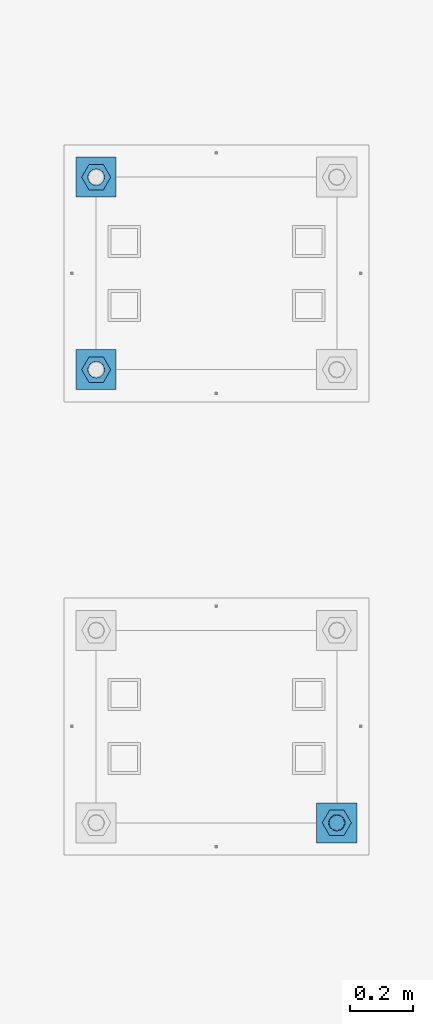
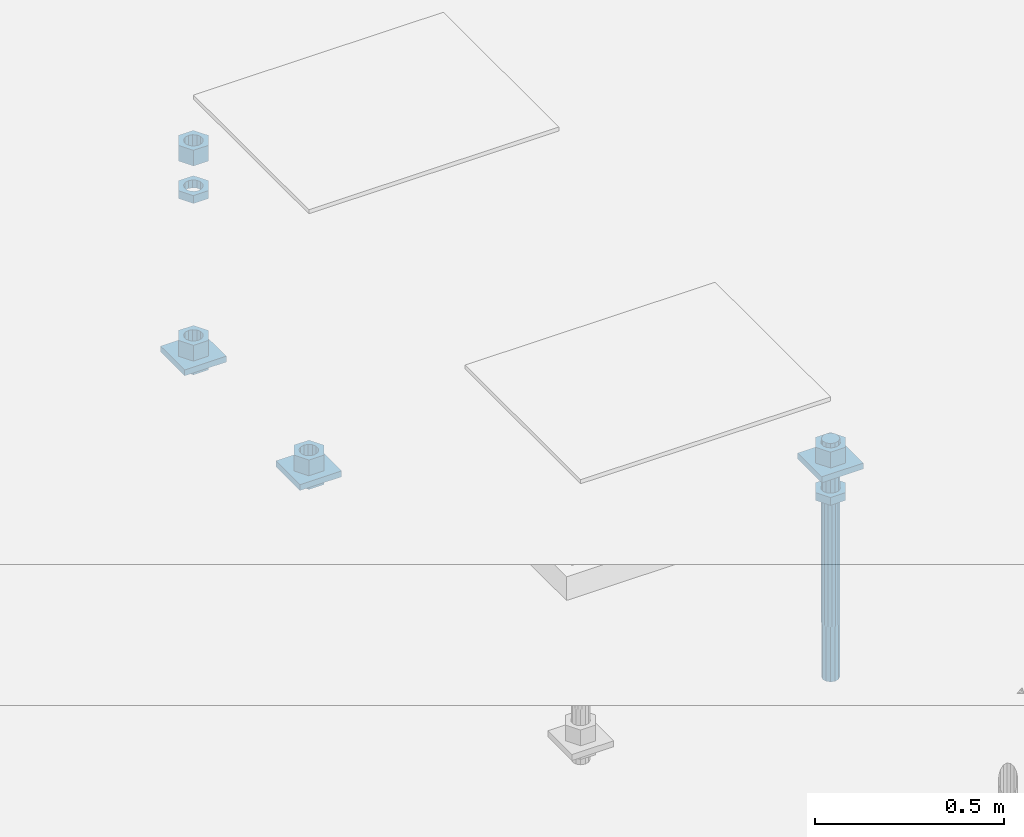
# One storey, part 2560 of 3843: 12 beams, 2 elements without a shape of their own.
"""IFC2X3 building model written with IfcOpenShell, lengths in millimetres."""

from ifc_helpers import new_model, si_unit, frame, origin_with_axes, place, context, subcontext, project, spatial, faceted_brep, material, type_object, element, aggregate, save


model = new_model("IFC2X3")

# Units and contexts
model_context = context("Model", 3, precision=1e-05, world=origin_with_axes())
body_context = subcontext(model_context, "Body", "Model", "MODEL_VIEW")
ifc_project = project(units=[si_unit("LENGTHUNIT", "METRE", prefix="MILLI"), si_unit("AREAUNIT", "SQUARE_METRE"), si_unit("VOLUMEUNIT", "CUBIC_METRE"), si_unit("MASSUNIT", "GRAM", prefix="KILO"), si_unit("TIMEUNIT", "SECOND"), si_unit("PLANEANGLEUNIT", "RADIAN"), si_unit("SOLIDANGLEUNIT", "STERADIAN"), si_unit("THERMODYNAMICTEMPERATUREUNIT", "DEGREE_CELSIUS"), si_unit("LUMINOUSINTENSITYUNIT", "LUMEN")], contexts=[model_context])

# Site, building, storey
site_placement = place(None, origin_with_axes())
site = spatial("IfcSite", under=ifc_project, at=site_placement, CompositionType="ELEMENT")
building_placement = place(site_placement, origin_with_axes())
building = spatial("IfcBuilding", under=site, at=building_placement, Name="Undefined", CompositionType="ELEMENT")
storey_placement = place(building_placement, origin_with_axes())
storey = spatial("IfcBuildingStorey", under=building, at=storey_placement, Name="Undefined", CompositionType="ELEMENT", Elevation=0.0)

# Assembly, beam
assembly_1_placement = place(storey_placement, origin_with_axes())
assembly_1 = element("IfcElementAssembly", 1, at=assembly_1_placement, inside=storey, Name="TEMPLATE", AssemblyPlace="NOTDEFINED", PredefinedType="RIGID_FRAME")
ifc_material_1 = material(Name="STEEL/A572-50")
beam_type_1 = type_object("IfcBeamType", PredefinedType="NOTDEFINED")
beam_1_placement = place(assembly_1_placement, frame((105537.0, 1282.70000152587, 29873.575), z_axis=(1.0, 0.0, 0.0), x_axis=(0.0, 1.0, 0.0)))
beam_1 = element("IfcBeam", 2, at=beam_1_placement, type_object=beam_type_1, material=ifc_material_1, Name="WASHER_PLATE", context=body_context, shape_type="Brep", body=[
    faceted_brep([(0.0, 9.52500000000146, -63.5), (0.0, 9.52500000000146, 63.5), (127.0, 9.52500000000146, 63.5), (127.0, 9.52500000000146, -63.5), (0.0, -9.52500000000146, 63.5), (127.0, -9.52500000000146, 63.5), (0.0, -9.52500000000146, -63.5), (127.0, -9.52500000000146, -63.5)], [[[0, 1, 2, 3]], [[1, 4, 5, 2]], [[4, 6, 7, 5]], [[6, 0, 3, 7]], [[5, 7, 3, 2]], [[6, 4, 1, 0]]]),
])

# Assembly, beams
assembly_2_placement = place(storey_placement, origin_with_axes())
assembly_2 = element("IfcElementAssembly", 3, at=assembly_2_placement, inside=storey, Name="TEMPLATE", AssemblyPlace="NOTDEFINED", PredefinedType="RIGID_FRAME")
beam_2_placement = place(assembly_2_placement, frame((104775.0, 2717.80000152587, 29244.925), z_axis=(1.0, 0.0, 0.0), x_axis=(0.0, 1.0, 0.0)))
beam_2 = element("IfcBeam", 4, at=beam_2_placement, type_object=beam_type_1, material=ifc_material_1, Name="WASHER_PLATE", context=body_context, shape_type="Brep", body=[
    faceted_brep([(0.0, 9.52500000000146, -63.5), (0.0, 9.52500000000146, 63.5), (127.0, 9.52500000000146, 63.5), (127.0, 9.52500000000146, -63.5), (0.0, -9.52500000000146, 63.5), (127.0, -9.52500000000146, 63.5), (0.0, -9.52500000000146, -63.5), (127.0, -9.52500000000146, -63.5)], [[[0, 1, 2, 3]], [[1, 4, 5, 2]], [[4, 6, 7, 5]], [[6, 0, 3, 7]], [[5, 7, 3, 2]], [[6, 4, 1, 0]]]),
])
beam_3_placement = place(assembly_2_placement, frame((104775.0, 3327.40000152587, 29244.925), z_axis=(1.0, 0.0, 0.0), x_axis=(0.0, 1.0, 0.0)))
beam_3 = element("IfcBeam", 5, at=beam_3_placement, type_object=beam_type_1, material=ifc_material_1, Name="WASHER_PLATE", context=body_context, shape_type="Brep", body=[
    faceted_brep([(0.0, 9.52500000000146, -63.5), (0.0, 9.52500000000146, 63.5), (127.0, 9.52500000000146, 63.5), (127.0, 9.52500000000146, -63.5), (0.0, -9.52500000000146, 63.5), (127.0, -9.52500000000146, 63.5), (0.0, -9.52500000000146, -63.5), (127.0, -9.52500000000146, -63.5)], [[[0, 1, 2, 3]], [[1, 4, 5, 2]], [[4, 6, 7, 5]], [[6, 0, 3, 7]], [[5, 7, 3, 2]], [[6, 4, 1, 0]]]),
])

# Beam
ifc_material_2 = material(Name="STEEL/A36")
beam_type_2 = type_object("IfcBeamType", Name="2_HALF_NUT", PredefinedType="NOTDEFINED")
beam_4_placement = place(assembly_1_placement, frame((105537.0, 1346.20000152587, 29787.85), z_axis=(0.0, 1.0, 0.0), x_axis=(0.0, 0.0, -1.0)))
beam_4 = element("IfcBeam", 6, at=beam_4_placement, type_object=beam_type_2, material=ifc_material_2, Name="NUT", ObjectType="2_HALF_NUT", context=body_context, shape_type="Brep", body=[
    faceted_brep([(0.0, -46.0369987487793, 0.0), (0.0, -23.0184993743896, -39.869213104248), (25.4000000000015, -23.0184993743896, -39.869213104248), (25.4000000000015, -46.0369987487793, 0.0), (0.0, 23.0184993743896, -39.869213104248), (25.4000000000015, 23.0184993743896, -39.869213104248), (0.0, 46.0369987487793, 0.0), (25.4000000000015, 46.0369987487793, 0.0), (0.0, 23.0184993743896, 39.869213104248), (25.4000000000015, 23.0184993743896, 39.869213104248), (0.0, -23.0184993743896, 39.869213104248), (25.4000000000015, -23.0184993743896, 39.869213104248), (0.0, 0.0, 26.1940002441406), (0.0, 11.3650617044477, 23.5999013092805), (25.4000000000015, 11.3650617044477, 23.5999013092805), (25.4000000000015, 0.0, 26.1940002441406), (0.0, 20.4791109456419, 16.3316083006721), (25.4000000000015, 20.4791109456419, 16.3316083006721), (0.0, 25.5370200498292, 5.82867859874386), (25.4000000000015, 25.5370200498292, 5.82867859874386), (0.0, 25.5370200498292, -5.82867859874386), (25.4000000000015, 25.5370200498292, -5.82867859874386), (0.0, 20.4791109456419, -16.3316083006721), (25.4000000000015, 20.4791109456419, -16.3316083006721), (0.0, 11.3650617044477, -23.5999013092805), (25.4000000000015, 11.3650617044477, -23.5999013092805), (0.0, 0.0, -26.1940002441406), (25.4000000000015, 0.0, -26.1940002441406), (0.0, -11.3650617044477, -23.5999013092805), (25.4000000000015, -11.3650617044477, -23.5999013092805), (0.0, -20.4791109456419, -16.3316083006721), (25.4000000000015, -20.4791109456419, -16.3316083006721), (0.0, -25.5370200498292, -5.82867859874386), (25.4000000000015, -25.5370200498292, -5.82867859874386), (0.0, -25.5370200498292, 5.82867859874386), (25.4000000000015, -25.5370200498292, 5.82867859874386), (0.0, -20.4791109456419, 16.3316083006721), (25.4000000000015, -20.4791109456419, 16.3316083006721), (0.0, -11.3650617044477, 23.5999013092805), (25.4000000000015, -11.3650617044477, 23.5999013092805)], [[[0, 1, 2, 3]], [[1, 4, 5, 2]], [[4, 6, 7, 5]], [[6, 8, 9, 7]], [[8, 10, 11, 9]], [[10, 0, 3, 11]], [[12, 13, 14, 15]], [[13, 16, 17, 14]], [[16, 18, 19, 17]], [[18, 20, 21, 19]], [[20, 22, 23, 21]], [[22, 24, 25, 23]], [[24, 26, 27, 25]], [[26, 28, 29, 27]], [[28, 30, 31, 29]], [[30, 32, 33, 31]], [[32, 34, 35, 33]], [[34, 36, 37, 35]], [[36, 38, 39, 37]], [[38, 12, 15, 39]], [[5, 7, 9, 11, 3, 2], [17, 19, 21, 23, 25, 27, 29, 31, 33, 35, 37, 39, 15, 14]], [[10, 8, 6, 4, 1, 0], [38, 36, 34, 32, 30, 28, 26, 24, 22, 20, 18, 16, 13, 12]]]),
])

beam_5_placement = place(assembly_2_placement, frame((104775.0, 2781.30000152587, 29235.4), z_axis=(0.0, 1.0, 0.0), x_axis=(0.0, 0.0, -1.0)))
beam_5 = element("IfcBeam", 7, at=beam_5_placement, type_object=beam_type_2, material=ifc_material_2, Name="NUT", ObjectType="2_HALF_NUT", context=body_context, shape_type="Brep", body=[
    faceted_brep([(0.0, -46.0369987487793, 0.0), (0.0, -23.0184993743896, -39.869213104248), (25.4000000000015, -23.0184993743896, -39.869213104248), (25.4000000000015, -46.0369987487793, 0.0), (0.0, 23.0184993743896, -39.869213104248), (25.4000000000015, 23.0184993743896, -39.869213104248), (0.0, 46.0369987487793, 0.0), (25.4000000000015, 46.0369987487793, 0.0), (0.0, 23.0184993743896, 39.869213104248), (25.4000000000015, 23.0184993743896, 39.869213104248), (0.0, -23.0184993743896, 39.869213104248), (25.4000000000015, -23.0184993743896, 39.869213104248), (0.0, 0.0, 26.1940002441406), (0.0, 11.3650617044477, 23.5999013092805), (25.4000000000015, 11.3650617044477, 23.5999013092805), (25.4000000000015, 0.0, 26.1940002441406), (0.0, 20.4791109456419, 16.3316083006721), (25.4000000000015, 20.4791109456419, 16.3316083006721), (0.0, 25.5370200498292, 5.82867859874386), (25.4000000000015, 25.5370200498292, 5.82867859874386), (0.0, 25.5370200498292, -5.82867859874386), (25.4000000000015, 25.5370200498292, -5.82867859874386), (0.0, 20.4791109456419, -16.3316083006721), (25.4000000000015, 20.4791109456419, -16.3316083006721), (0.0, 11.3650617044477, -23.5999013092805), (25.4000000000015, 11.3650617044477, -23.5999013092805), (0.0, 0.0, -26.1940002441406), (25.4000000000015, 0.0, -26.1940002441406), (0.0, -11.3650617044477, -23.5999013092805), (25.4000000000015, -11.3650617044477, -23.5999013092805), (0.0, -20.4791109456419, -16.3316083006721), (25.4000000000015, -20.4791109456419, -16.3316083006721), (0.0, -25.5370200498292, -5.82867859874386), (25.4000000000015, -25.5370200498292, -5.82867859874386), (0.0, -25.5370200498292, 5.82867859874386), (25.4000000000015, -25.5370200498292, 5.82867859874386), (0.0, -20.4791109456419, 16.3316083006721), (25.4000000000015, -20.4791109456419, 16.3316083006721), (0.0, -11.3650617044477, 23.5999013092805), (25.4000000000015, -11.3650617044477, 23.5999013092805)], [[[0, 1, 2, 3]], [[1, 4, 5, 2]], [[4, 6, 7, 5]], [[6, 8, 9, 7]], [[8, 10, 11, 9]], [[10, 0, 3, 11]], [[12, 13, 14, 15]], [[13, 16, 17, 14]], [[16, 18, 19, 17]], [[18, 20, 21, 19]], [[20, 22, 23, 21]], [[22, 24, 25, 23]], [[24, 26, 27, 25]], [[26, 28, 29, 27]], [[28, 30, 31, 29]], [[30, 32, 33, 31]], [[32, 34, 35, 33]], [[34, 36, 37, 35]], [[36, 38, 39, 37]], [[38, 12, 15, 39]], [[5, 7, 9, 11, 3, 2], [17, 19, 21, 23, 25, 27, 29, 31, 33, 35, 37, 39, 15, 14]], [[10, 8, 6, 4, 1, 0], [38, 36, 34, 32, 30, 28, 26, 24, 22, 20, 18, 16, 13, 12]]]),
])

beam_6_placement = place(assembly_2_placement, frame((104775.0, 3390.90000152587, 29787.85), z_axis=(0.0, 1.0, 0.0), x_axis=(0.0, 0.0, -1.0)))
beam_6 = element("IfcBeam", 8, at=beam_6_placement, type_object=beam_type_2, material=ifc_material_2, Name="NUT", ObjectType="2_HALF_NUT", context=body_context, shape_type="Brep", body=[
    faceted_brep([(0.0, -46.0369987487793, 0.0), (0.0, -23.0184993743896, -39.869213104248), (25.4000000000015, -23.0184993743896, -39.869213104248), (25.4000000000015, -46.0369987487793, 0.0), (0.0, 23.0184993743896, -39.869213104248), (25.4000000000015, 23.0184993743896, -39.869213104248), (0.0, 46.0369987487793, 0.0), (25.4000000000015, 46.0369987487793, 0.0), (0.0, 23.0184993743896, 39.869213104248), (25.4000000000015, 23.0184993743896, 39.869213104248), (0.0, -23.0184993743896, 39.869213104248), (25.4000000000015, -23.0184993743896, 39.869213104248), (0.0, 0.0, 26.1940002441406), (0.0, 11.3650617044477, 23.5999013092805), (25.4000000000015, 11.3650617044477, 23.5999013092805), (25.4000000000015, 0.0, 26.1940002441406), (0.0, 20.4791109456419, 16.3316083006721), (25.4000000000015, 20.4791109456419, 16.3316083006721), (0.0, 25.5370200498292, 5.82867859874386), (25.4000000000015, 25.5370200498292, 5.82867859874386), (0.0, 25.5370200498292, -5.82867859874386), (25.4000000000015, 25.5370200498292, -5.82867859874386), (0.0, 20.4791109456419, -16.3316083006721), (25.4000000000015, 20.4791109456419, -16.3316083006721), (0.0, 11.3650617044477, -23.5999013092805), (25.4000000000015, 11.3650617044477, -23.5999013092805), (0.0, 0.0, -26.1940002441406), (25.4000000000015, 0.0, -26.1940002441406), (0.0, -11.3650617044477, -23.5999013092805), (25.4000000000015, -11.3650617044477, -23.5999013092805), (0.0, -20.4791109456419, -16.3316083006721), (25.4000000000015, -20.4791109456419, -16.3316083006721), (0.0, -25.5370200498292, -5.82867859874386), (25.4000000000015, -25.5370200498292, -5.82867859874386), (0.0, -25.5370200498292, 5.82867859874386), (25.4000000000015, -25.5370200498292, 5.82867859874386), (0.0, -20.4791109456419, 16.3316083006721), (25.4000000000015, -20.4791109456419, 16.3316083006721), (0.0, -11.3650617044477, 23.5999013092805), (25.4000000000015, -11.3650617044477, 23.5999013092805)], [[[0, 1, 2, 3]], [[1, 4, 5, 2]], [[4, 6, 7, 5]], [[6, 8, 9, 7]], [[8, 10, 11, 9]], [[10, 0, 3, 11]], [[12, 13, 14, 15]], [[13, 16, 17, 14]], [[16, 18, 19, 17]], [[18, 20, 21, 19]], [[20, 22, 23, 21]], [[22, 24, 25, 23]], [[24, 26, 27, 25]], [[26, 28, 29, 27]], [[28, 30, 31, 29]], [[30, 32, 33, 31]], [[32, 34, 35, 33]], [[34, 36, 37, 35]], [[36, 38, 39, 37]], [[38, 12, 15, 39]], [[5, 7, 9, 11, 3, 2], [17, 19, 21, 23, 25, 27, 29, 31, 33, 35, 37, 39, 15, 14]], [[10, 8, 6, 4, 1, 0], [38, 36, 34, 32, 30, 28, 26, 24, 22, 20, 18, 16, 13, 12]]]),
])

beam_7_placement = place(assembly_2_placement, frame((104775.0, 3390.90000152587, 29235.4), z_axis=(0.0, 1.0, 0.0), x_axis=(0.0, 0.0, -1.0)))
beam_7 = element("IfcBeam", 9, at=beam_7_placement, type_object=beam_type_2, material=ifc_material_2, Name="NUT", ObjectType="2_HALF_NUT", context=body_context, shape_type="Brep", body=[
    faceted_brep([(0.0, -46.0369987487793, 0.0), (0.0, -23.0184993743896, -39.869213104248), (25.4000000000015, -23.0184993743896, -39.869213104248), (25.4000000000015, -46.0369987487793, 0.0), (0.0, 23.0184993743896, -39.869213104248), (25.4000000000015, 23.0184993743896, -39.869213104248), (0.0, 46.0369987487793, 0.0), (25.4000000000015, 46.0369987487793, 0.0), (0.0, 23.0184993743896, 39.869213104248), (25.4000000000015, 23.0184993743896, 39.869213104248), (0.0, -23.0184993743896, 39.869213104248), (25.4000000000015, -23.0184993743896, 39.869213104248), (0.0, 0.0, 26.1940002441406), (0.0, 11.3650617044477, 23.5999013092805), (25.4000000000015, 11.3650617044477, 23.5999013092805), (25.4000000000015, 0.0, 26.1940002441406), (0.0, 20.4791109456419, 16.3316083006721), (25.4000000000015, 20.4791109456419, 16.3316083006721), (0.0, 25.5370200498292, 5.82867859874386), (25.4000000000015, 25.5370200498292, 5.82867859874386), (0.0, 25.5370200498292, -5.82867859874386), (25.4000000000015, 25.5370200498292, -5.82867859874386), (0.0, 20.4791109456419, -16.3316083006721), (25.4000000000015, 20.4791109456419, -16.3316083006721), (0.0, 11.3650617044477, -23.5999013092805), (25.4000000000015, 11.3650617044477, -23.5999013092805), (0.0, 0.0, -26.1940002441406), (25.4000000000015, 0.0, -26.1940002441406), (0.0, -11.3650617044477, -23.5999013092805), (25.4000000000015, -11.3650617044477, -23.5999013092805), (0.0, -20.4791109456419, -16.3316083006721), (25.4000000000015, -20.4791109456419, -16.3316083006721), (0.0, -25.5370200498292, -5.82867859874386), (25.4000000000015, -25.5370200498292, -5.82867859874386), (0.0, -25.5370200498292, 5.82867859874386), (25.4000000000015, -25.5370200498292, 5.82867859874386), (0.0, -20.4791109456419, 16.3316083006721), (25.4000000000015, -20.4791109456419, 16.3316083006721), (0.0, -11.3650617044477, 23.5999013092805), (25.4000000000015, -11.3650617044477, 23.5999013092805)], [[[0, 1, 2, 3]], [[1, 4, 5, 2]], [[4, 6, 7, 5]], [[6, 8, 9, 7]], [[8, 10, 11, 9]], [[10, 0, 3, 11]], [[12, 13, 14, 15]], [[13, 16, 17, 14]], [[16, 18, 19, 17]], [[18, 20, 21, 19]], [[20, 22, 23, 21]], [[22, 24, 25, 23]], [[24, 26, 27, 25]], [[26, 28, 29, 27]], [[28, 30, 31, 29]], [[30, 32, 33, 31]], [[32, 34, 35, 33]], [[34, 36, 37, 35]], [[36, 38, 39, 37]], [[38, 12, 15, 39]], [[5, 7, 9, 11, 3, 2], [17, 19, 21, 23, 25, 27, 29, 31, 33, 35, 37, 39, 15, 14]], [[10, 8, 6, 4, 1, 0], [38, 36, 34, 32, 30, 28, 26, 24, 22, 20, 18, 16, 13, 12]]]),
])

beam_type_3 = type_object("IfcBeamType", Name="2_HEAVY_HEX_NUT", PredefinedType="NOTDEFINED")
beam_8_placement = place(assembly_1_placement, frame((105537.0, 1346.20000152587, 29933.9), z_axis=(0.0, 1.0, 0.0), x_axis=(0.0, 0.0, -1.0)))
beam_8 = element("IfcBeam", 10, at=beam_8_placement, type_object=beam_type_3, material=ifc_material_2, Name="NUT", ObjectType="2_HEAVY_HEX_NUT", context=body_context, shape_type="Brep", body=[
    faceted_brep([(0.0, -46.0369987487793, 0.0), (0.0, -23.0184993743896, -39.869213104248), (50.7999999999993, -23.0184993743896, -39.869213104248), (50.7999999999993, -46.0369987487793, 0.0), (0.0, 23.0184993743896, -39.869213104248), (50.7999999999993, 23.0184993743896, -39.869213104248), (0.0, 46.0369987487793, 0.0), (50.7999999999993, 46.0369987487793, 0.0), (0.0, 23.0184993743896, 39.869213104248), (50.7999999999993, 23.0184993743896, 39.869213104248), (0.0, -23.0184993743896, 39.869213104248), (50.7999999999993, -23.0184993743896, 39.869213104248), (0.0, 0.0, 26.1940002441406), (0.0, 11.3650617044477, 23.5999013092805), (50.7999999999993, 11.3650617044477, 23.5999013092805), (50.7999999999993, 0.0, 26.1940002441406), (0.0, 20.4791109456419, 16.3316083006721), (50.7999999999993, 20.4791109456419, 16.3316083006721), (0.0, 25.5370200498292, 5.82867859874386), (50.7999999999993, 25.5370200498292, 5.82867859874386), (0.0, 25.5370200498292, -5.82867859874386), (50.7999999999993, 25.5370200498292, -5.82867859874386), (0.0, 20.4791109456419, -16.3316083006721), (50.7999999999993, 20.4791109456419, -16.3316083006721), (0.0, 11.3650617044477, -23.5999013092805), (50.7999999999993, 11.3650617044477, -23.5999013092805), (0.0, 0.0, -26.1940002441406), (50.7999999999993, 0.0, -26.1940002441406), (0.0, -11.3650617044477, -23.5999013092805), (50.7999999999993, -11.3650617044477, -23.5999013092805), (0.0, -20.4791109456419, -16.3316083006721), (50.7999999999993, -20.4791109456419, -16.3316083006721), (0.0, -25.5370200498292, -5.82867859874386), (50.7999999999993, -25.5370200498292, -5.82867859874386), (0.0, -25.5370200498292, 5.82867859874386), (50.7999999999993, -25.5370200498292, 5.82867859874386), (0.0, -20.4791109456419, 16.3316083006721), (50.7999999999993, -20.4791109456419, 16.3316083006721), (0.0, -11.3650617044477, 23.5999013092805), (50.7999999999993, -11.3650617044477, 23.5999013092805)], [[[0, 1, 2, 3]], [[1, 4, 5, 2]], [[4, 6, 7, 5]], [[6, 8, 9, 7]], [[8, 10, 11, 9]], [[10, 0, 3, 11]], [[12, 13, 14, 15]], [[13, 16, 17, 14]], [[16, 18, 19, 17]], [[18, 20, 21, 19]], [[20, 22, 23, 21]], [[22, 24, 25, 23]], [[24, 26, 27, 25]], [[26, 28, 29, 27]], [[28, 30, 31, 29]], [[30, 32, 33, 31]], [[32, 34, 35, 33]], [[34, 36, 37, 35]], [[36, 38, 39, 37]], [[38, 12, 15, 39]], [[5, 7, 9, 11, 3, 2], [17, 19, 21, 23, 25, 27, 29, 31, 33, 35, 37, 39, 15, 14]], [[10, 8, 6, 4, 1, 0], [38, 36, 34, 32, 30, 28, 26, 24, 22, 20, 18, 16, 13, 12]]]),
])

beam_9_placement = place(assembly_2_placement, frame((104775.0, 2781.30000152587, 29305.25), z_axis=(0.0, 1.0, 0.0), x_axis=(0.0, 0.0, -1.0)))
beam_9 = element("IfcBeam", 11, at=beam_9_placement, type_object=beam_type_3, material=ifc_material_2, Name="NUT", ObjectType="2_HEAVY_HEX_NUT", context=body_context, shape_type="Brep", body=[
    faceted_brep([(0.0, -46.0369987487793, 0.0), (0.0, -23.0184993743896, -39.869213104248), (50.7999999999993, -23.0184993743896, -39.869213104248), (50.7999999999993, -46.0369987487793, 0.0), (0.0, 23.0184993743896, -39.869213104248), (50.7999999999993, 23.0184993743896, -39.869213104248), (0.0, 46.0369987487793, 0.0), (50.7999999999993, 46.0369987487793, 0.0), (0.0, 23.0184993743896, 39.869213104248), (50.7999999999993, 23.0184993743896, 39.869213104248), (0.0, -23.0184993743896, 39.869213104248), (50.7999999999993, -23.0184993743896, 39.869213104248), (0.0, 0.0, 26.1940002441406), (0.0, 11.3650617044477, 23.5999013092805), (50.7999999999993, 11.3650617044477, 23.5999013092805), (50.7999999999993, 0.0, 26.1940002441406), (0.0, 20.4791109456419, 16.3316083006721), (50.7999999999993, 20.4791109456419, 16.3316083006721), (0.0, 25.5370200498292, 5.82867859874386), (50.7999999999993, 25.5370200498292, 5.82867859874386), (0.0, 25.5370200498292, -5.82867859874386), (50.7999999999993, 25.5370200498292, -5.82867859874386), (0.0, 20.4791109456419, -16.3316083006721), (50.7999999999993, 20.4791109456419, -16.3316083006721), (0.0, 11.3650617044477, -23.5999013092805), (50.7999999999993, 11.3650617044477, -23.5999013092805), (0.0, 0.0, -26.1940002441406), (50.7999999999993, 0.0, -26.1940002441406), (0.0, -11.3650617044477, -23.5999013092805), (50.7999999999993, -11.3650617044477, -23.5999013092805), (0.0, -20.4791109456419, -16.3316083006721), (50.7999999999993, -20.4791109456419, -16.3316083006721), (0.0, -25.5370200498292, -5.82867859874386), (50.7999999999993, -25.5370200498292, -5.82867859874386), (0.0, -25.5370200498292, 5.82867859874386), (50.7999999999993, -25.5370200498292, 5.82867859874386), (0.0, -20.4791109456419, 16.3316083006721), (50.7999999999993, -20.4791109456419, 16.3316083006721), (0.0, -11.3650617044477, 23.5999013092805), (50.7999999999993, -11.3650617044477, 23.5999013092805)], [[[0, 1, 2, 3]], [[1, 4, 5, 2]], [[4, 6, 7, 5]], [[6, 8, 9, 7]], [[8, 10, 11, 9]], [[10, 0, 3, 11]], [[12, 13, 14, 15]], [[13, 16, 17, 14]], [[16, 18, 19, 17]], [[18, 20, 21, 19]], [[20, 22, 23, 21]], [[22, 24, 25, 23]], [[24, 26, 27, 25]], [[26, 28, 29, 27]], [[28, 30, 31, 29]], [[30, 32, 33, 31]], [[32, 34, 35, 33]], [[34, 36, 37, 35]], [[36, 38, 39, 37]], [[38, 12, 15, 39]], [[5, 7, 9, 11, 3, 2], [17, 19, 21, 23, 25, 27, 29, 31, 33, 35, 37, 39, 15, 14]], [[10, 8, 6, 4, 1, 0], [38, 36, 34, 32, 30, 28, 26, 24, 22, 20, 18, 16, 13, 12]]]),
])

beam_10_placement = place(assembly_2_placement, frame((104775.0, 3390.90000152587, 29933.9), z_axis=(0.0, 1.0, 0.0), x_axis=(0.0, 0.0, -1.0)))
beam_10 = element("IfcBeam", 12, at=beam_10_placement, type_object=beam_type_3, material=ifc_material_2, Name="NUT", ObjectType="2_HEAVY_HEX_NUT", context=body_context, shape_type="Brep", body=[
    faceted_brep([(0.0, -46.0369987487793, 0.0), (0.0, -23.0184993743896, -39.869213104248), (50.7999999999993, -23.0184993743896, -39.869213104248), (50.7999999999993, -46.0369987487793, 0.0), (0.0, 23.0184993743896, -39.869213104248), (50.7999999999993, 23.0184993743896, -39.869213104248), (0.0, 46.0369987487793, 0.0), (50.7999999999993, 46.0369987487793, 0.0), (0.0, 23.0184993743896, 39.869213104248), (50.7999999999993, 23.0184993743896, 39.869213104248), (0.0, -23.0184993743896, 39.869213104248), (50.7999999999993, -23.0184993743896, 39.869213104248), (0.0, 0.0, 26.1940002441406), (0.0, 11.3650617044477, 23.5999013092805), (50.7999999999993, 11.3650617044477, 23.5999013092805), (50.7999999999993, 0.0, 26.1940002441406), (0.0, 20.4791109456419, 16.3316083006721), (50.7999999999993, 20.4791109456419, 16.3316083006721), (0.0, 25.5370200498292, 5.82867859874386), (50.7999999999993, 25.5370200498292, 5.82867859874386), (0.0, 25.5370200498292, -5.82867859874386), (50.7999999999993, 25.5370200498292, -5.82867859874386), (0.0, 20.4791109456419, -16.3316083006721), (50.7999999999993, 20.4791109456419, -16.3316083006721), (0.0, 11.3650617044477, -23.5999013092805), (50.7999999999993, 11.3650617044477, -23.5999013092805), (0.0, 0.0, -26.1940002441406), (50.7999999999993, 0.0, -26.1940002441406), (0.0, -11.3650617044477, -23.5999013092805), (50.7999999999993, -11.3650617044477, -23.5999013092805), (0.0, -20.4791109456419, -16.3316083006721), (50.7999999999993, -20.4791109456419, -16.3316083006721), (0.0, -25.5370200498292, -5.82867859874386), (50.7999999999993, -25.5370200498292, -5.82867859874386), (0.0, -25.5370200498292, 5.82867859874386), (50.7999999999993, -25.5370200498292, 5.82867859874386), (0.0, -20.4791109456419, 16.3316083006721), (50.7999999999993, -20.4791109456419, 16.3316083006721), (0.0, -11.3650617044477, 23.5999013092805), (50.7999999999993, -11.3650617044477, 23.5999013092805)], [[[0, 1, 2, 3]], [[1, 4, 5, 2]], [[4, 6, 7, 5]], [[6, 8, 9, 7]], [[8, 10, 11, 9]], [[10, 0, 3, 11]], [[12, 13, 14, 15]], [[13, 16, 17, 14]], [[16, 18, 19, 17]], [[18, 20, 21, 19]], [[20, 22, 23, 21]], [[22, 24, 25, 23]], [[24, 26, 27, 25]], [[26, 28, 29, 27]], [[28, 30, 31, 29]], [[30, 32, 33, 31]], [[32, 34, 35, 33]], [[34, 36, 37, 35]], [[36, 38, 39, 37]], [[38, 12, 15, 39]], [[5, 7, 9, 11, 3, 2], [17, 19, 21, 23, 25, 27, 29, 31, 33, 35, 37, 39, 15, 14]], [[10, 8, 6, 4, 1, 0], [38, 36, 34, 32, 30, 28, 26, 24, 22, 20, 18, 16, 13, 12]]]),
])

beam_11_placement = place(assembly_2_placement, frame((104775.0, 3390.90000152587, 29305.25), z_axis=(0.0, 1.0, 0.0), x_axis=(0.0, 0.0, -1.0)))
beam_11 = element("IfcBeam", 13, at=beam_11_placement, type_object=beam_type_3, material=ifc_material_2, Name="NUT", ObjectType="2_HEAVY_HEX_NUT", context=body_context, shape_type="Brep", body=[
    faceted_brep([(0.0, -46.0369987487793, 0.0), (0.0, -23.0184993743896, -39.869213104248), (50.7999999999993, -23.0184993743896, -39.869213104248), (50.7999999999993, -46.0369987487793, 0.0), (0.0, 23.0184993743896, -39.869213104248), (50.7999999999993, 23.0184993743896, -39.869213104248), (0.0, 46.0369987487793, 0.0), (50.7999999999993, 46.0369987487793, 0.0), (0.0, 23.0184993743896, 39.869213104248), (50.7999999999993, 23.0184993743896, 39.869213104248), (0.0, -23.0184993743896, 39.869213104248), (50.7999999999993, -23.0184993743896, 39.869213104248), (0.0, 0.0, 26.1940002441406), (0.0, 11.3650617044477, 23.5999013092805), (50.7999999999993, 11.3650617044477, 23.5999013092805), (50.7999999999993, 0.0, 26.1940002441406), (0.0, 20.4791109456419, 16.3316083006721), (50.7999999999993, 20.4791109456419, 16.3316083006721), (0.0, 25.5370200498292, 5.82867859874386), (50.7999999999993, 25.5370200498292, 5.82867859874386), (0.0, 25.5370200498292, -5.82867859874386), (50.7999999999993, 25.5370200498292, -5.82867859874386), (0.0, 20.4791109456419, -16.3316083006721), (50.7999999999993, 20.4791109456419, -16.3316083006721), (0.0, 11.3650617044477, -23.5999013092805), (50.7999999999993, 11.3650617044477, -23.5999013092805), (0.0, 0.0, -26.1940002441406), (50.7999999999993, 0.0, -26.1940002441406), (0.0, -11.3650617044477, -23.5999013092805), (50.7999999999993, -11.3650617044477, -23.5999013092805), (0.0, -20.4791109456419, -16.3316083006721), (50.7999999999993, -20.4791109456419, -16.3316083006721), (0.0, -25.5370200498292, -5.82867859874386), (50.7999999999993, -25.5370200498292, -5.82867859874386), (0.0, -25.5370200498292, 5.82867859874386), (50.7999999999993, -25.5370200498292, 5.82867859874386), (0.0, -20.4791109456419, 16.3316083006721), (50.7999999999993, -20.4791109456419, 16.3316083006721), (0.0, -11.3650617044477, 23.5999013092805), (50.7999999999993, -11.3650617044477, 23.5999013092805)], [[[0, 1, 2, 3]], [[1, 4, 5, 2]], [[4, 6, 7, 5]], [[6, 8, 9, 7]], [[8, 10, 11, 9]], [[10, 0, 3, 11]], [[12, 13, 14, 15]], [[13, 16, 17, 14]], [[16, 18, 19, 17]], [[18, 20, 21, 19]], [[20, 22, 23, 21]], [[22, 24, 25, 23]], [[24, 26, 27, 25]], [[26, 28, 29, 27]], [[28, 30, 31, 29]], [[30, 32, 33, 31]], [[32, 34, 35, 33]], [[34, 36, 37, 35]], [[36, 38, 39, 37]], [[38, 12, 15, 39]], [[5, 7, 9, 11, 3, 2], [17, 19, 21, 23, 25, 27, 29, 31, 33, 35, 37, 39, 15, 14]], [[10, 8, 6, 4, 1, 0], [38, 36, 34, 32, 30, 28, 26, 24, 22, 20, 18, 16, 13, 12]]]),
])

aggregate(assembly_2, [beam_9, beam_5, beam_2, beam_6, beam_10, beam_11, beam_7, beam_3])

ifc_material_3 = material()
beam_type_4 = type_object("IfcBeamType", PredefinedType="NOTDEFINED")
beam_12_placement = place(assembly_1_placement, frame((105537.000001526, 1346.19999999998, 29762.45), z_axis=(1.0, 0.0, 0.0), x_axis=(0.0, 0.0, -1.0)))
beam_12 = element("IfcBeam", 14, at=beam_12_placement, type_object=beam_type_4, material=ifc_material_3, Name="ANCHOR_ROD", context=body_context, shape_type="Brep", body=[
    faceted_brep([(0.0, -23.4665401257807, -9.72015918207035), (0.0, -17.9605122421344, -17.9605122421417), (406.399999999998, -17.9605122421344, -17.9605122421417), (406.399999999998, -23.4665401257807, -9.72015918207035), (0.0, -9.72015918207762, -23.466540125788), (406.399999999998, -9.72015918207762, -23.466540125788), (0.0, 0.0, -25.4000000000015), (406.399999999998, 0.0, -25.4000000000015), (0.0, 9.72015918207762, -23.466540125788), (406.399999999998, 9.72015918207762, -23.466540125788), (0.0, 17.9605122421344, -17.9605122421417), (406.399999999998, 17.9605122421344, -17.9605122421417), (0.0, 23.4665401257807, -9.72015918207035), (406.399999999998, 23.4665401257807, -9.72015918207035), (0.0, 25.3999996185303, 0.0), (406.399999999998, 25.3999999999942, 0.0), (0.0, 23.4665401257807, 9.72015918207035), (406.399999999998, 23.4665401257807, 9.72015918207035), (0.0, 17.9605122421344, 17.9605122421417), (406.399999999998, 17.9605122421344, 17.9605122421417), (0.0, 9.72015918207762, 23.466540125788), (406.399999999998, 9.72015918207762, 23.466540125788), (0.0, 0.0, 25.4000000000015), (406.399999999998, 0.0, 25.4000000000015), (0.0, -9.72015918207762, 23.466540125788), (406.399999999998, -9.72015918207762, 23.466540125788), (0.0, -17.9605122421344, 17.9605122421417), (406.399999999998, -17.9605122421344, 17.9605122421417), (0.0, -23.4665401257807, 9.72015918207035), (406.399999999998, -23.4665401257807, 9.72015918207035), (0.0, -25.3999996185303, 0.0), (406.399999999998, -25.3999999999942, 0.0), (584.200000000001, -12.2499999999854, -21.2176223927163), (584.200000000001, 1.45519152283669e-11, -24.5), (584.200000000001, 12.2500000000146, -21.2176223927163), (584.200000000001, 21.2176223927381, -12.25), (584.200000000001, 24.5000000000146, 0.0), (584.200000000001, 21.2176223927381, 12.25), (584.200000000001, 12.2500000000146, 21.2176223927163), (584.200000000001, 1.45519152283669e-11, 24.5), (584.200000000001, -12.2499999999854, 21.2176223927163), (584.200000000001, -21.217622392709, 12.25), (584.200000000001, -24.4999999999854, 0.0), (584.200000000001, -21.217622392709, -12.25), (406.399999999998, -24.4999999999854, 0.0), (406.399999999998, -21.217622392709, -12.25), (406.399999999998, -12.2499999999854, -21.2176223927163), (406.399999999998, 1.45519152283669e-11, -24.5), (406.399999999998, 12.2500000000146, -21.2176223927163), (406.399999999998, 21.2176223927381, -12.25), (406.399999999998, 24.5000000000146, 0.0), (406.399999999998, 21.2176223927381, 12.25), (406.399999999998, 12.2500000000146, 21.2176223927163), (406.399999999998, 1.45519152283669e-11, 24.5), (406.399999999998, -12.2499999999854, 21.2176223927163), (406.399999999998, -21.217622392709, 12.25), (0.0, 12.2500000000146, 21.2176223927163), (0.0, 1.45519152283669e-11, 24.5), (0.0, -12.2499999999854, 21.2176223927163), (0.0, -21.217622392709, 12.25), (0.0, -24.4999999999854, 0.0), (0.0, -21.217622392709, -12.25), (0.0, -12.2499999999854, -21.2176223927163), (0.0, 1.45519152283669e-11, -24.5), (0.0, 12.2500000000146, -21.2176223927163), (0.0, 21.2176223927381, -12.25), (0.0, 24.5000000000146, 0.0), (0.0, 21.2176223927381, 12.25), (-184.150000000001, -21.217622392709, 12.25), (-184.150000000001, -12.2499999999854, 21.2176223927163), (-184.150000000001, 1.45519152283669e-11, 24.5), (-184.150000000001, 12.2500000000146, 21.2176223927163), (-184.150000000001, 21.2176223927381, 12.25), (-184.150000000001, 24.5000000000146, 0.0), (-184.150000000001, 21.2176223927381, -12.25), (-184.150000000001, 12.2500000000146, -21.2176223927163), (-184.150000000001, 1.45519152283669e-11, -24.5), (-184.150000000001, -12.2499999999854, -21.2176223927163), (-184.150000000001, -21.217622392709, -12.25), (-184.150000000001, -24.4999999999854, 0.0)], [[[0, 1, 2, 3]], [[1, 4, 5, 2]], [[4, 6, 7, 5]], [[6, 8, 9, 7]], [[8, 10, 11, 9]], [[10, 12, 13, 11]], [[12, 14, 15, 13]], [[14, 16, 17, 15]], [[16, 18, 19, 17]], [[18, 20, 21, 19]], [[20, 22, 23, 21]], [[22, 24, 25, 23]], [[24, 26, 27, 25]], [[26, 28, 29, 27]], [[28, 30, 31, 29]], [[32, 33, 34, 35, 36, 37, 38, 39, 40, 41, 42, 43]], [[43, 42, 44, 45]], [[32, 43, 45, 46]], [[33, 32, 46, 47]], [[34, 33, 47, 48]], [[35, 34, 48, 49]], [[36, 35, 49, 50]], [[37, 36, 50, 51]], [[38, 37, 51, 52]], [[39, 38, 52, 53]], [[40, 39, 53, 54]], [[41, 40, 54, 55]], [[42, 41, 55, 44]], [[2, 5, 7, 9, 11, 13, 15, 17, 19, 21, 23, 25, 27, 29, 31, 3], [54, 53, 52, 51, 50, 49, 48, 47, 46, 45, 44, 55]], [[30, 0, 3, 31]], [[28, 26, 24, 22, 20, 18, 16, 14, 12, 10, 8, 6, 4, 1, 0, 30], [56, 57, 58, 59, 60, 61, 62, 63, 64, 65, 66, 67]], [[68, 69, 70, 71, 72, 73, 74, 75, 76, 77, 78, 79]], [[71, 70, 57, 56]], [[72, 71, 56, 67]], [[73, 72, 67, 66]], [[74, 73, 66, 65]], [[75, 74, 65, 64]], [[76, 75, 64, 63]], [[77, 76, 63, 62]], [[78, 77, 62, 61]], [[79, 78, 61, 60]], [[68, 79, 60, 59]], [[69, 68, 59, 58]], [[70, 69, 58, 57]]]),
])

aggregate(assembly_1, [beam_12, beam_1, beam_4, beam_8])

save(model, "model.ifc")
